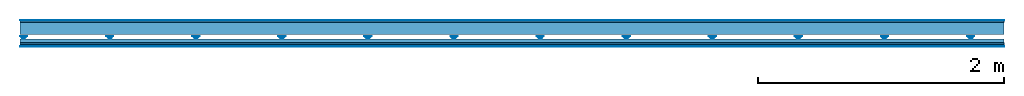
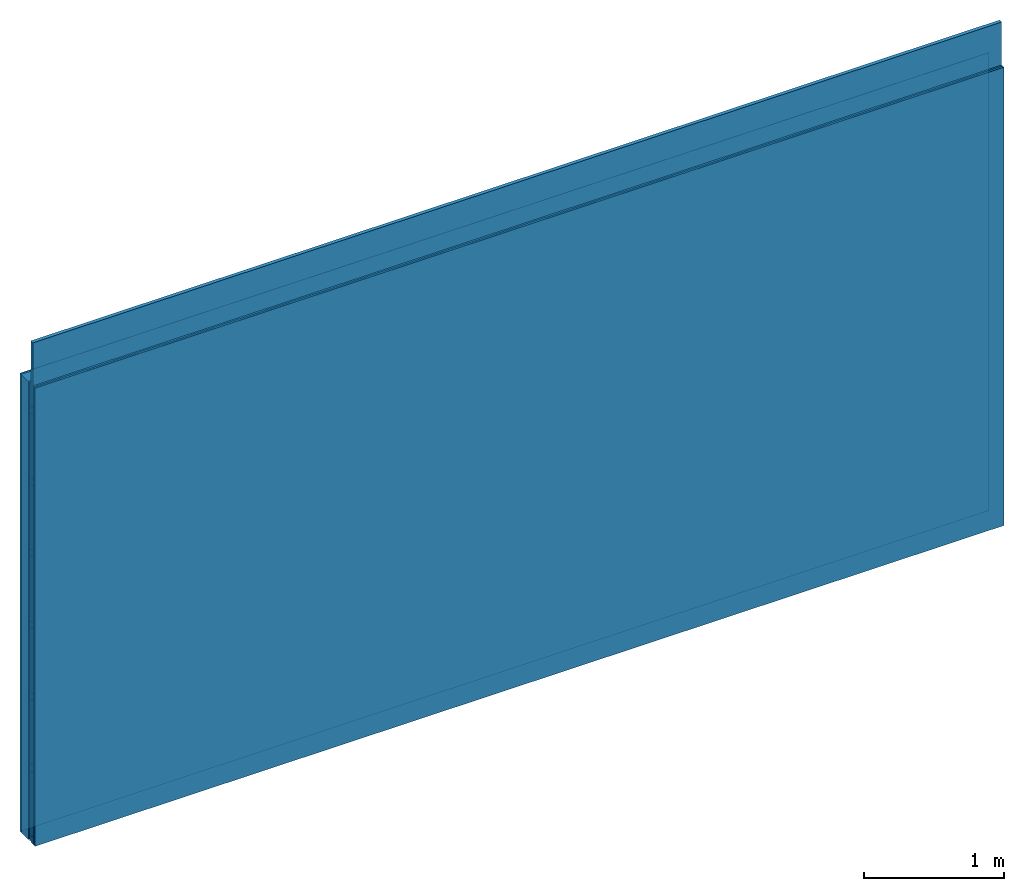
# One storey: 5 plates, 4 members, 1 element without a shape of its own.
"""IFC4 building model written with IfcOpenShell, lengths in metres."""

import ifcopenshell
import ifcopenshell.guid

model = None  # the IFC model being written
_history = None  # IfcOwnerHistory: only IFC2X3 demands one
_inside = {}  # id of a spatial element -> (the spatial element, [elements in it])
_under = {}  # id of a project, library or spatial element -> (it, [spatial elements below it])
_declared = {}  # id of a project -> (the project, [libraries it declares])
_typed = {}  # id of a type object -> (the type object, [elements of that type])
_made_of = {}  # id of a material, layer set ... -> (it, [elements and type objects made of it])


def new_model(schema):
    """Start an empty IFC model of exactly this schema.

    Asked for "IFC4X3", IfcOpenShell would pick the latest addendum, in which some entities
    have other attributes; the version numbers below select the first issue.
    IFC2X3 requires an IfcOwnerHistory on every rooted entity: one is made here for all.
    """
    global model, _history
    if schema == "IFC4X3":
        model = ifcopenshell.file(schema_version=(4, 3, 0, 0))
    else:
        model = ifcopenshell.file(schema=schema)
    _inside.clear()
    _under.clear()
    _declared.clear()
    _typed.clear()
    _made_of.clear()
    _history = None
    if model.schema == "IFC2X3":
        org = make("IfcOrganization", Name="unknown")
        user = make(
            "IfcPersonAndOrganization",
            ThePerson=make("IfcPerson", FamilyName="unknown"),
            TheOrganization=org,
        )
        app = make(
            "IfcApplication",
            ApplicationDeveloper=org,
            Version="unknown",
            ApplicationFullName="unknown",
            ApplicationIdentifier="unknown",
        )
        _history = make(
            "IfcOwnerHistory",
            OwningUser=user,
            OwningApplication=app,
            ChangeAction="ADDED",
            CreationDate=0,
        )
    return model


def make(cls, **values):
    """One entity of the class cls with the attributes given. An attribute that is None is left unset."""
    return model.create_entity(
        cls, **{name: value for name, value in values.items() if value is not None}
    )


def rooted(cls, **values):
    """An entity with a GlobalId (a new one), such as an element, a storey or a relation."""
    return make(cls, GlobalId=ifcopenshell.guid.new(), OwnerHistory=_history, **values)


def si_unit(unit_type, name, prefix=None):
    """IfcSIUnit, for example si_unit("LENGTHUNIT", "METRE", prefix="MILLI")."""
    return make("IfcSIUnit", UnitType=unit_type, Prefix=prefix, Name=name)


def derived_unit(unit_type, elements):
    """IfcDerivedUnit: a product of units, each with its exponent."""
    return make(
        "IfcDerivedUnit",
        Elements=[
            make("IfcDerivedUnitElement", Unit=unit, Exponent=power)
            for unit, power in elements
        ],
        UnitType=unit_type,
    )


def assignment(units):
    """IfcUnitAssignment: the units of a project."""
    return None if units is None else make("IfcUnitAssignment", Units=units)


def point(xyz):
    """IfcCartesianPoint."""
    return None if xyz is None else make("IfcCartesianPoint", Coordinates=xyz)


def direction(xyz):
    """IfcDirection."""
    return None if xyz is None else make("IfcDirection", DirectionRatios=xyz)


def frame(location, z_axis=None, x_axis=None):
    """IfcAxis2Placement3D, a coordinate frame: its origin and axes. An axis left out is left unset."""
    return make(
        "IfcAxis2Placement3D",
        Location=point(location),
        Axis=direction(z_axis),
        RefDirection=direction(x_axis),
    )


def frame_2d(location, x_axis=None):
    """IfcAxis2Placement2D, a coordinate frame in the plane: its origin and x axis."""
    return make(
        "IfcAxis2Placement2D", Location=point(location), RefDirection=direction(x_axis)
    )


def origin():
    """The frame at (0, 0, 0) with its axes left unset."""
    return frame((0.0, 0.0, 0.0))


def origin_with_axes():
    """The frame at (0, 0, 0) with the z axis (0, 0, 1) and the x axis (1, 0, 0) written out."""
    return frame((0.0, 0.0, 0.0), z_axis=(0.0, 0.0, 1.0), x_axis=(1.0, 0.0, 0.0))


def place(relative_to, where):
    """IfcLocalPlacement: puts the frame where relative to a parent placement (None: the world)."""
    return make(
        "IfcLocalPlacement", PlacementRelTo=relative_to, RelativePlacement=where
    )


def context(
    kind, dimensions, precision=None, world=None, true_north=None, identifier=None
):
    """IfcGeometricRepresentationContext, for example the 3D "Model" context."""
    return make(
        "IfcGeometricRepresentationContext",
        ContextIdentifier=identifier,
        ContextType=kind,
        CoordinateSpaceDimension=dimensions,
        Precision=precision,
        WorldCoordinateSystem=world,
        TrueNorth=true_north,
    )


def project(units=None, contexts=None):
    """IfcProject with its units and contexts."""
    return rooted(
        "IfcProject",
        Name="project",
        RepresentationContexts=contexts,
        UnitsInContext=assignment(units),
    )


def spatial(cls, under=None, at=None, **own):
    """A site, building, storey or space (cls), placed at a placement, below another one or the project."""
    s = rooted(cls, ObjectPlacement=at, **own)
    if under is not None:
        _under.setdefault(under.id(), (under, []))[1].append(s)
    return s


def polyline(points):
    """IfcPolyline through the points."""
    return make("IfcPolyline", Points=[point(p) for p in points])


def profile(cls, at=None, kind="AREA", **sizes):
    """A parametric profile (cls). Its sizes go by their IFC names, for example OverallWidth=200.0."""
    return make(cls, ProfileType=kind, Position=at, **sizes)


def rectangle(**sizes):
    """IfcRectangleProfileDef."""
    return profile("IfcRectangleProfileDef", **sizes)


def outline(outer, holes=None, kind="AREA"):
    """IfcArbitraryClosedProfileDef: a profile drawn as a closed curve; with holes, ...WithVoids."""
    if holes is None:
        return make("IfcArbitraryClosedProfileDef", ProfileType=kind, OuterCurve=outer)
    return make(
        "IfcArbitraryProfileDefWithVoids",
        ProfileType=kind,
        OuterCurve=outer,
        InnerCurves=holes,
    )


def extrude(swept, where, along, depth):
    """IfcExtrudedAreaSolid: the profile swept, set in the frame where, extruded along a direction by depth."""
    return make(
        "IfcExtrudedAreaSolid",
        SweptArea=swept,
        Position=where,
        ExtrudedDirection=direction(along),
        Depth=depth,
    )


def shape(context_of_items, identifier, shape_type, items):
    """IfcShapeRepresentation: the items that make up one representation, for example the "Body"."""
    return make(
        "IfcShapeRepresentation",
        ContextOfItems=context_of_items,
        RepresentationIdentifier=identifier,
        RepresentationType=shape_type,
        Items=items,
    )


def material(Name=None, Category=None):
    """IfcMaterial."""
    return make("IfcMaterial", Name=Name, Category=Category)


def layer(
    of_material, thickness, ventilated=None, Name=None, Category=None, Priority=None
):
    """IfcMaterialLayer: one layer of a wall or slab, of a material (None: an air gap)."""
    return make(
        "IfcMaterialLayer",
        Material=of_material,
        LayerThickness=thickness,
        IsVentilated=ventilated,
        Name=Name,
        Category=Category,
        Priority=Priority,
    )


def layer_set(layers, Name=None):
    """IfcMaterialLayerSet."""
    return make("IfcMaterialLayerSet", MaterialLayers=layers, LayerSetName=Name)


def made_of(thing, what):
    """Note that an element or type object is made of a material, layer set ...; save() writes the relation."""
    if what is not None:
        _made_of.setdefault(what.id(), (what, []))[1].append(thing)
    return thing


def type_object(cls, material=None, **own):
    """A type object (cls), such as IfcWallType, which elements share."""
    return made_of(rooted(cls, **own), material)


def element(
    cls,
    number,
    at=None,
    inside=None,
    cuts=None,
    type_object=None,
    material=None,
    context=None,
    identifier="Body",
    shape_type=None,
    held_by="IfcProductDefinitionShape",
    body=None,
    shapes=None,
    **own,
):
    """One element of the class cls, such as IfcWall. Its Tag is "e" and its number.

    at: its placement. inside: the storey or other place that contains it. cuts: it is an
    opening in that element (IfcRelVoidsElement). A single representation is given by context,
    identifier, shape_type and body (its items); several are given by shapes. held_by: the class
    of the entity that holds the representations. save() writes the other relations.
    """
    e = rooted(cls, Tag="e%d" % number, ObjectPlacement=at, **own)
    if body is not None:
        shapes = [shape(context, identifier, shape_type, body)]
    if shapes is not None:
        e.Representation = make(held_by, Representations=shapes)
    if inside is not None:
        _inside.setdefault(inside.id(), (inside, []))[1].append(e)
    if cuts is not None:
        rooted(
            "IfcRelVoidsElement", RelatingBuildingElement=cuts, RelatedOpeningElement=e
        )
    if type_object is not None:
        _typed.setdefault(type_object.id(), (type_object, []))[1].append(e)
    return made_of(e, material)


def aggregate(whole, parts):
    """IfcRelAggregates: a whole, such as a stair, and the parts it consists of."""
    return rooted("IfcRelAggregates", RelatingObject=whole, RelatedObjects=parts)


def save(model, path):
    """Write the relations noted so far, then the file.

    IfcRelAggregates (storeys below a building ...), IfcRelContainedInSpatialStructure (elements
    in a storey), IfcRelDefinesByType, IfcRelAssociatesMaterial and IfcRelDeclares: one each for
    every whole, place, type object, material and project.
    """
    for whole, parts in _under.values():
        aggregate(whole, parts)
    for where, things in _inside.values():
        rooted(
            "IfcRelContainedInSpatialStructure",
            RelatedElements=things,
            RelatingStructure=where,
        )
    for kind, things in _typed.values():
        rooted("IfcRelDefinesByType", RelatedObjects=things, RelatingType=kind)
    for what, things in _made_of.values():
        rooted("IfcRelAssociatesMaterial", RelatedObjects=things, RelatingMaterial=what)
    for by, libraries in _declared.values():
        rooted("IfcRelDeclares", RelatingContext=by, RelatedDefinitions=libraries)
    model.write(path)


model = new_model("IFC4")

# Units and contexts
plan_context = context("Plan", 3, precision=1e-05, world=origin(), true_north=direction((0.0, 1.0)))
model_context = context("Model", 3, precision=1e-05, world=origin(), true_north=direction((0.0, 1.0)))
ifc_project = project(units=[si_unit("LENGTHUNIT", "METRE"), derived_unit("SOUNDPRESSUREUNIT", [(si_unit("PRESSUREUNIT", "PASCAL", prefix="MICRO"), 0)]), si_unit("ENERGYUNIT", "JOULE", prefix="MEGA"), si_unit("MASSUNIT", "GRAM", prefix="KILO"), derived_unit("THERMALTRANSMITTANCEUNIT", [(si_unit("POWERUNIT", "WATT"), 1), (si_unit("AREAUNIT", "SQUARE_METRE"), -1), (si_unit("THERMODYNAMICTEMPERATUREUNIT", "KELVIN"), -1)]), derived_unit("AREADENSITYUNIT", [(si_unit("MASSUNIT", "GRAM", prefix="KILO"), 1), (si_unit("AREAUNIT", "SQUARE_METRE"), -1)]), derived_unit("USERDEFINED", [(si_unit("ENERGYUNIT", "JOULE", prefix="MEGA"), 1), (si_unit("AREAUNIT", "SQUARE_METRE"), -1)])], contexts=[plan_context, model_context])

# Site, building, storey
site = spatial("IfcSite", under=ifc_project)
building_placement = place(None, origin())
building = spatial("IfcBuilding", under=site, at=building_placement)
storey_placement = place(building_placement, origin())
storey = spatial("IfcBuildingStorey", under=building, at=storey_placement)

# Wall, members, plates
ifc_material_1 = material(Category="04.001")
ifc_layer_1 = layer(ifc_material_1, 0.003, Name="Surface")
ifc_material_2 = material(Name="DFH2IR Knauf Diamant hard- plasterboard", Category="03.007")
ifc_layer_2 = layer(ifc_material_2, 0.015, Name="1st layer")
ifc_material_3 = material(Name="of the art")
ifc_layer_3 = layer(ifc_material_3, 0.0, Name="Bond")
ifc_layer_4 = layer(None, 0.1, Name="Support")
ifc_layer_5 = layer(None, 0.036, Name="Coupling")
ifc_layer_6 = layer(None, 0.03, Name="Battens / profiles")
ifc_layer_7 = layer(ifc_material_2, 0.015, Name="Covering 1st layer")
ifc_layer_8 = layer(ifc_material_2, 0.015, Name="Covering 2nd layer")
ifc_layer_9 = layer(ifc_material_1, 0.003, Name="Surface")
ifc_layer_set = layer_set([ifc_layer_1, ifc_layer_2, ifc_layer_3, ifc_layer_4, ifc_layer_5, ifc_layer_6, ifc_layer_7, ifc_layer_8, ifc_layer_9])
wall_type = type_object("IfcWallType", Name="C0380", PredefinedType="NOTDEFINED", material=ifc_layer_set)
wall_placement = place(None, frame((0.0, 0.0, 0.0), z_axis=(0.0, -1.0, 0.0), x_axis=(1.0, 0.0, 0.0)))
wall = element("IfcWall", 1, at=wall_placement, inside=storey, type_object=wall_type, material=ifc_layer_set, Name="Wall #1")
ifc_material_4 = material(Name="Solid timber panel")
member_1_placement = place(wall_placement, origin())
member_1 = element("IfcMember", 2, at=member_1_placement, material=ifc_material_4, Name="Support", context=plan_context, shape_type="SweptSolid", body=[
    extrude(rectangle(XDim=1.0, YDim=0.1, at=frame_2d((0.5, 0.05), x_axis=(1.0, 0.0))), frame((0.0, 4.0, 0.018), z_axis=(0.0, -1.0, 0.0), x_axis=(1.0, 0.0, 0.0)), (0.0, 0.0, 1.0), 4.0),
    extrude(rectangle(XDim=1.0, YDim=0.1, at=frame_2d((0.5, 0.05), x_axis=(1.0, 0.0))), frame((1.0, 4.0, 0.018), z_axis=(0.0, -1.0, 0.0), x_axis=(1.0, 0.0, 0.0)), (0.0, 0.0, 1.0), 4.0),
    extrude(rectangle(XDim=1.0, YDim=0.1, at=frame_2d((0.5, 0.05), x_axis=(1.0, 0.0))), frame((2.0, 4.0, 0.018), z_axis=(0.0, -1.0, 0.0), x_axis=(1.0, 0.0, 0.0)), (0.0, 0.0, 1.0), 4.0),
    extrude(rectangle(XDim=1.0, YDim=0.1, at=frame_2d((0.5, 0.05), x_axis=(1.0, 0.0))), frame((3.0, 4.0, 0.018), z_axis=(0.0, -1.0, 0.0), x_axis=(1.0, 0.0, 0.0)), (0.0, 0.0, 1.0), 4.0),
    extrude(rectangle(XDim=1.0, YDim=0.1, at=frame_2d((0.5, 0.05), x_axis=(1.0, 0.0))), frame((4.0, 4.0, 0.018), z_axis=(0.0, -1.0, 0.0), x_axis=(1.0, 0.0, 0.0)), (0.0, 0.0, 1.0), 4.0),
    extrude(rectangle(XDim=1.0, YDim=0.1, at=frame_2d((0.5, 0.05), x_axis=(1.0, 0.0))), frame((5.0, 4.0, 0.018), z_axis=(0.0, -1.0, 0.0), x_axis=(1.0, 0.0, 0.0)), (0.0, 0.0, 1.0), 4.0),
    extrude(rectangle(XDim=1.0, YDim=0.1, at=frame_2d((0.5, 0.05), x_axis=(1.0, 0.0))), frame((6.0, 4.0, 0.018), z_axis=(0.0, -1.0, 0.0), x_axis=(1.0, 0.0, 0.0)), (0.0, 0.0, 1.0), 4.0),
    extrude(rectangle(XDim=1.0, YDim=0.1, at=frame_2d((0.5, 0.05), x_axis=(1.0, 0.0))), frame((7.0, 4.0, 0.018), z_axis=(0.0, -1.0, 0.0), x_axis=(1.0, 0.0, 0.0)), (0.0, 0.0, 1.0), 4.0),
])
ifc_material_5 = material()
member_2_placement = place(wall_placement, origin())
member_2 = element("IfcMember", 3, at=member_2_placement, material=ifc_material_5, Name="Coupling", context=plan_context, shape_type="SweptSolid", body=[
    extrude(outline(polyline([(0.0, 0.0), (0.06, 0.0), (0.04, 0.02), (0.02, 0.02), (0.0, 0.0)])), frame((0.0, 4.0, 0.134), z_axis=(0.0, -1.0, 0.0), x_axis=(1.0, 0.0, 0.0)), (0.0, 0.0, 1.0), 4.0),
    extrude(outline(polyline([(0.0, 0.0), (0.06, 0.0), (0.04, 0.02), (0.02, 0.02), (0.0, 0.0)])), frame((0.7, 4.0, 0.134), z_axis=(0.0, -1.0, 0.0), x_axis=(1.0, 0.0, 0.0)), (0.0, 0.0, 1.0), 4.0),
    extrude(outline(polyline([(0.0, 0.0), (0.06, 0.0), (0.04, 0.02), (0.02, 0.02), (0.0, 0.0)])), frame((1.4, 4.0, 0.134), z_axis=(0.0, -1.0, 0.0), x_axis=(1.0, 0.0, 0.0)), (0.0, 0.0, 1.0), 4.0),
    extrude(outline(polyline([(0.0, 0.0), (0.06, 0.0), (0.04, 0.02), (0.02, 0.02), (0.0, 0.0)])), frame((2.1, 4.0, 0.134), z_axis=(0.0, -1.0, 0.0), x_axis=(1.0, 0.0, 0.0)), (0.0, 0.0, 1.0), 4.0),
    extrude(outline(polyline([(0.0, 0.0), (0.06, 0.0), (0.04, 0.02), (0.02, 0.02), (0.0, 0.0)])), frame((2.8, 4.0, 0.134), z_axis=(0.0, -1.0, 0.0), x_axis=(1.0, 0.0, 0.0)), (0.0, 0.0, 1.0), 4.0),
    extrude(outline(polyline([(0.0, 0.0), (0.06, 0.0), (0.04, 0.02), (0.02, 0.02), (0.0, 0.0)])), frame((3.5, 4.0, 0.134), z_axis=(0.0, -1.0, 0.0), x_axis=(1.0, 0.0, 0.0)), (0.0, 0.0, 1.0), 4.0),
    extrude(outline(polyline([(0.0, 0.0), (0.06, 0.0), (0.04, 0.02), (0.02, 0.02), (0.0, 0.0)])), frame((4.2, 4.0, 0.134), z_axis=(0.0, -1.0, 0.0), x_axis=(1.0, 0.0, 0.0)), (0.0, 0.0, 1.0), 4.0),
    extrude(outline(polyline([(0.0, 0.0), (0.06, 0.0), (0.04, 0.02), (0.02, 0.02), (0.0, 0.0)])), frame((4.9, 4.0, 0.134), z_axis=(0.0, -1.0, 0.0), x_axis=(1.0, 0.0, 0.0)), (0.0, 0.0, 1.0), 4.0),
    extrude(outline(polyline([(0.0, 0.0), (0.06, 0.0), (0.04, 0.02), (0.02, 0.02), (0.0, 0.0)])), frame((5.6, 4.0, 0.134), z_axis=(0.0, -1.0, 0.0), x_axis=(1.0, 0.0, 0.0)), (0.0, 0.0, 1.0), 4.0),
    extrude(outline(polyline([(0.0, 0.0), (0.06, 0.0), (0.04, 0.02), (0.02, 0.02), (0.0, 0.0)])), frame((6.3, 4.0, 0.134), z_axis=(0.0, -1.0, 0.0), x_axis=(1.0, 0.0, 0.0)), (0.0, 0.0, 1.0), 4.0),
    extrude(outline(polyline([(0.0, 0.0), (0.06, 0.0), (0.04, 0.02), (0.02, 0.02), (0.0, 0.0)])), frame((7.0, 4.0, 0.134), z_axis=(0.0, -1.0, 0.0), x_axis=(1.0, 0.0, 0.0)), (0.0, 0.0, 1.0), 4.0),
    extrude(outline(polyline([(0.0, 0.0), (0.06, 0.0), (0.04, 0.02), (0.02, 0.02), (0.0, 0.0)])), frame((7.7, 4.0, 0.134), z_axis=(0.0, -1.0, 0.0), x_axis=(1.0, 0.0, 0.0)), (0.0, 0.0, 1.0), 4.0),
])
member_3_placement = place(wall_placement, origin())
member_3 = element("IfcMember", 4, at=member_3_placement, material=ifc_material_5, Name="Battens / profiles", context=plan_context, shape_type="SweptSolid", body=[
    extrude(rectangle(XDim=0.06, YDim=0.03, at=frame_2d((0.03, 0.015), x_axis=(1.0, 0.0))), frame((0.0, 0.0, 0.154), z_axis=(1.0, 0.0, 0.0), x_axis=(0.0, 1.0, 0.0)), (0.0, 0.0, 1.0), 8.0),
    extrude(rectangle(XDim=0.06, YDim=0.03, at=frame_2d((0.03, 0.015), x_axis=(1.0, 0.0))), frame((0.0, 0.625, 0.154), z_axis=(1.0, 0.0, 0.0), x_axis=(0.0, 1.0, 0.0)), (0.0, 0.0, 1.0), 8.0),
    extrude(rectangle(XDim=0.06, YDim=0.03, at=frame_2d((0.03, 0.015), x_axis=(1.0, 0.0))), frame((0.0, 1.25, 0.154), z_axis=(1.0, 0.0, 0.0), x_axis=(0.0, 1.0, 0.0)), (0.0, 0.0, 1.0), 8.0),
    extrude(rectangle(XDim=0.06, YDim=0.03, at=frame_2d((0.03, 0.015), x_axis=(1.0, 0.0))), frame((0.0, 1.875, 0.154), z_axis=(1.0, 0.0, 0.0), x_axis=(0.0, 1.0, 0.0)), (0.0, 0.0, 1.0), 8.0),
    extrude(rectangle(XDim=0.06, YDim=0.03, at=frame_2d((0.03, 0.015), x_axis=(1.0, 0.0))), frame((0.0, 2.5, 0.154), z_axis=(1.0, 0.0, 0.0), x_axis=(0.0, 1.0, 0.0)), (0.0, 0.0, 1.0), 8.0),
    extrude(rectangle(XDim=0.06, YDim=0.03, at=frame_2d((0.03, 0.015), x_axis=(1.0, 0.0))), frame((0.0, 3.125, 0.154), z_axis=(1.0, 0.0, 0.0), x_axis=(0.0, 1.0, 0.0)), (0.0, 0.0, 1.0), 8.0),
    extrude(rectangle(XDim=0.06, YDim=0.03, at=frame_2d((0.03, 0.015), x_axis=(1.0, 0.0))), frame((0.0, 3.75, 0.154), z_axis=(1.0, 0.0, 0.0), x_axis=(0.0, 1.0, 0.0)), (0.0, 0.0, 1.0), 8.0),
])
ifc_material_6 = material()
member_4_placement = place(wall_placement, origin())
member_4 = element("IfcMember", 5, at=member_4_placement, material=ifc_material_6, Name="Cavity", context=plan_context, shape_type="SweptSolid", body=[
    extrude(rectangle(XDim=0.565, YDim=0.03, at=frame_2d((0.2825, 0.015), x_axis=(1.0, 0.0))), frame((0.0, 0.06, 0.154), z_axis=(1.0, 0.0, 0.0), x_axis=(0.0, 1.0, 0.0)), (0.0, 0.0, 1.0), 8.0),
    extrude(rectangle(XDim=0.565, YDim=0.03, at=frame_2d((0.2825, 0.015), x_axis=(1.0, 0.0))), frame((0.0, 0.685, 0.154), z_axis=(1.0, 0.0, 0.0), x_axis=(0.0, 1.0, 0.0)), (0.0, 0.0, 1.0), 8.0),
    extrude(rectangle(XDim=0.565, YDim=0.03, at=frame_2d((0.2825, 0.015), x_axis=(1.0, 0.0))), frame((0.0, 1.31, 0.154), z_axis=(1.0, 0.0, 0.0), x_axis=(0.0, 1.0, 0.0)), (0.0, 0.0, 1.0), 8.0),
    extrude(rectangle(XDim=0.565, YDim=0.03, at=frame_2d((0.2825, 0.015), x_axis=(1.0, 0.0))), frame((0.0, 1.935, 0.154), z_axis=(1.0, 0.0, 0.0), x_axis=(0.0, 1.0, 0.0)), (0.0, 0.0, 1.0), 8.0),
    extrude(rectangle(XDim=0.565, YDim=0.03, at=frame_2d((0.2825, 0.015), x_axis=(1.0, 0.0))), frame((0.0, 2.56, 0.154), z_axis=(1.0, 0.0, 0.0), x_axis=(0.0, 1.0, 0.0)), (0.0, 0.0, 1.0), 8.0),
    extrude(rectangle(XDim=0.565, YDim=0.03, at=frame_2d((0.2825, 0.015), x_axis=(1.0, 0.0))), frame((0.0, 3.185, 0.154), z_axis=(1.0, 0.0, 0.0), x_axis=(0.0, 1.0, 0.0)), (0.0, 0.0, 1.0), 8.0),
    extrude(rectangle(XDim=0.565, YDim=0.03, at=frame_2d((0.2825, 0.015), x_axis=(1.0, 0.0))), frame((0.0, 3.81, 0.154), z_axis=(1.0, 0.0, 0.0), x_axis=(0.0, 1.0, 0.0)), (0.0, 0.0, 1.0), 8.0),
])
plate_1_placement = place(wall_placement, origin())
plate_1 = element("IfcPlate", 6, at=plate_1_placement, material=ifc_material_1, Name="Surface", context=plan_context, shape_type="SweptSolid", body=[
    extrude(rectangle(XDim=8.0, YDim=4.0, at=frame_2d((4.0, 2.0), x_axis=(1.0, 0.0))), origin_with_axes(), (0.0, 0.0, 1.0), 0.003),
])
plate_2_placement = place(wall_placement, origin())
plate_2 = element("IfcPlate", 7, at=plate_2_placement, material=ifc_material_2, Name="1st layer", context=plan_context, shape_type="SweptSolid", body=[
    extrude(rectangle(XDim=8.0, YDim=4.0, at=frame_2d((4.0, 2.0), x_axis=(1.0, 0.0))), frame((0.0, 0.0, 0.003), z_axis=(0.0, 0.0, 1.0), x_axis=(1.0, 0.0, 0.0)), (0.0, 0.0, 1.0), 0.015),
])
plate_3_placement = place(wall_placement, origin())
plate_3 = element("IfcPlate", 8, at=plate_3_placement, material=ifc_material_2, Name="Covering 1st layer", context=plan_context, shape_type="SweptSolid", body=[
    extrude(rectangle(XDim=8.0, YDim=4.0, at=frame_2d((4.0, 2.0), x_axis=(1.0, 0.0))), frame((0.0, 0.0, 0.184), z_axis=(0.0, 0.0, 1.0), x_axis=(1.0, 0.0, 0.0)), (0.0, 0.0, 1.0), 0.015),
])
plate_4_placement = place(wall_placement, origin())
plate_4 = element("IfcPlate", 9, at=plate_4_placement, material=ifc_material_2, Name="Covering 2nd layer", context=plan_context, shape_type="SweptSolid", body=[
    extrude(rectangle(XDim=8.0, YDim=4.0, at=frame_2d((4.0, 2.0), x_axis=(1.0, 0.0))), frame((0.0, 0.0, 0.199), z_axis=(0.0, 0.0, 1.0), x_axis=(1.0, 0.0, 0.0)), (0.0, 0.0, 1.0), 0.015),
])
plate_5_placement = place(wall_placement, origin())
plate_5 = element("IfcPlate", 10, at=plate_5_placement, material=ifc_material_1, Name="Surface", context=plan_context, shape_type="SweptSolid", body=[
    extrude(rectangle(XDim=8.0, YDim=4.0, at=frame_2d((4.0, 2.0), x_axis=(1.0, 0.0))), frame((0.0, 0.0, 0.214), z_axis=(0.0, 0.0, 1.0), x_axis=(1.0, 0.0, 0.0)), (0.0, 0.0, 1.0), 0.003),
])
aggregate(wall, [plate_1, plate_2, member_1, member_2, member_3, member_4, plate_3, plate_4, plate_5])

save(model, "model.ifc")
